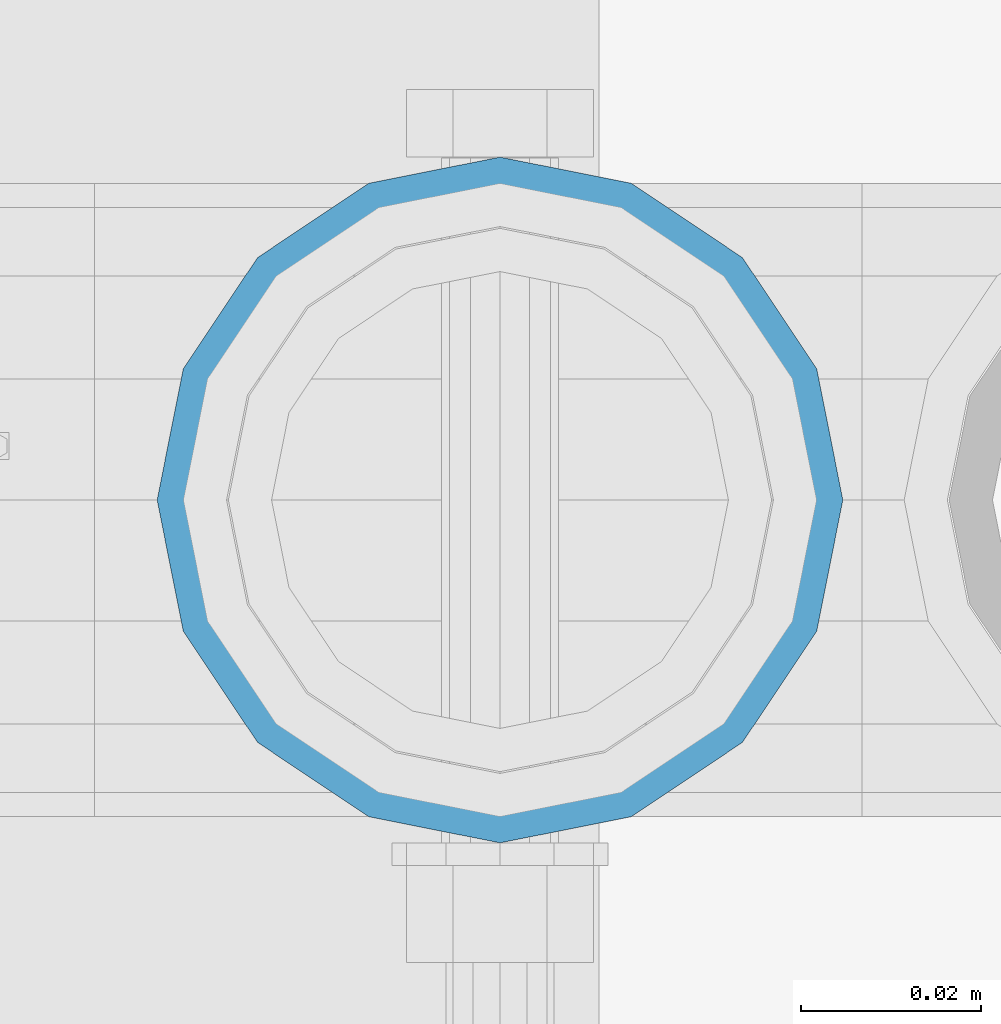
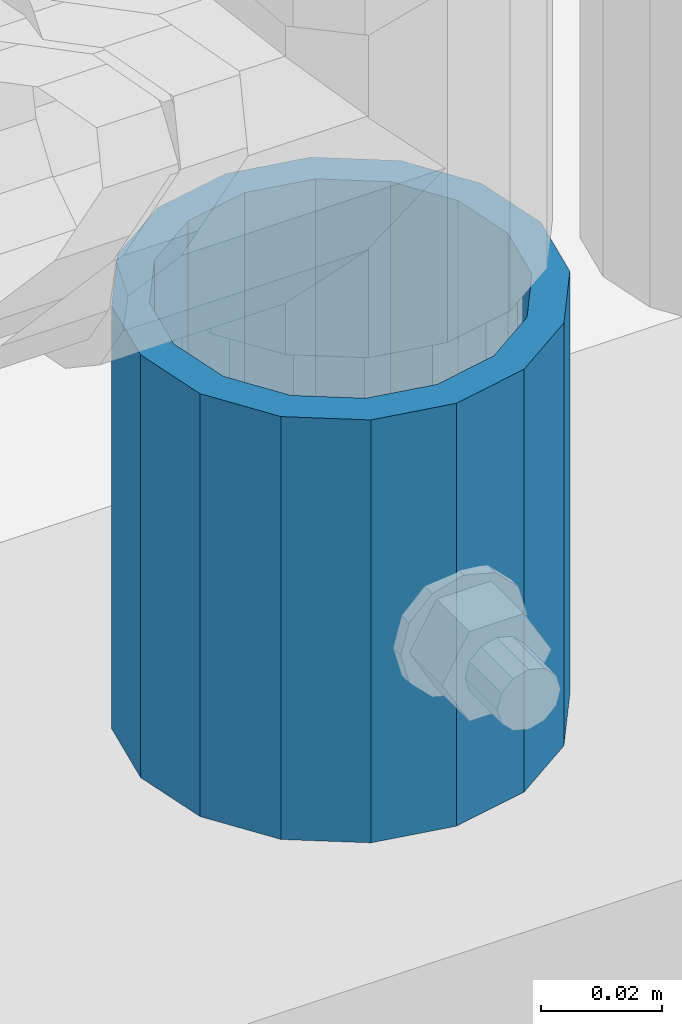
# One storey, part 113 of 270: 1 column.
"""IFC2X3 building model written with IfcOpenShell, lengths in millimetres."""

from ifc_helpers import new_model, si_unit, frame, origin_with_axes, place, context, subcontext, project, spatial, faceted_brep, material, type_object, element, save


model = new_model("IFC2X3")

# Units and contexts
model_context = context("Model", 3, precision=1e-05, world=origin_with_axes())
body_context = subcontext(model_context, "Body", "Model", "MODEL_VIEW")
ifc_project = project(units=[si_unit("LENGTHUNIT", "METRE", prefix="MILLI"), si_unit("AREAUNIT", "SQUARE_METRE"), si_unit("VOLUMEUNIT", "CUBIC_METRE"), si_unit("MASSUNIT", "GRAM", prefix="KILO"), si_unit("TIMEUNIT", "SECOND"), si_unit("PLANEANGLEUNIT", "RADIAN"), si_unit("SOLIDANGLEUNIT", "STERADIAN"), si_unit("THERMODYNAMICTEMPERATUREUNIT", "DEGREE_CELSIUS"), si_unit("LUMINOUSINTENSITYUNIT", "LUMEN")], contexts=[model_context])

# Site, building, storey
site_placement = place(None, origin_with_axes())
site = spatial("IfcSite", under=ifc_project, at=site_placement, CompositionType="ELEMENT")
building_placement = place(site_placement, origin_with_axes())
building = spatial("IfcBuilding", under=site, at=building_placement, Name="Standard", CompositionType="ELEMENT")
storey_placement = place(building_placement, origin_with_axes())
storey = spatial("IfcBuildingStorey", under=building, at=storey_placement, Name="Undefined", CompositionType="ELEMENT", Elevation=0.0)

# Column
ifc_material = material()
column_type = type_object("IfcColumnType", PredefinedType="NOTDEFINED")
column_placement = place(storey_placement, frame((19794.0, -16335.5, 168.02), z_axis=(0.0, 1.0, 0.0), x_axis=(0.0, 0.0, 1.0)))
element("IfcColumn", 1, at=column_placement, inside=storey, type_object=column_type, material=ifc_material, context=body_context, shape_type="Brep", body=[
    faceted_brep([(0.0, -31.75, 0.0), (0.0, -29.3331751572332, 12.1501989775916), (85.0, -29.3331751572332, 12.1501989775916), (85.0, -31.75, 0.0), (0.0, -22.4506403026717, 22.4506403026735), (85.0, -22.4506403026717, 22.4506403026735), (0.0, -12.1501989775934, 29.3331751572332), (85.0, -12.1501989775934, 29.3331751572332), (0.0, 0.0, 31.75), (85.0, 0.0, 31.75), (0.0, 12.1501989775934, 29.3331751572332), (85.0, 12.1501989775934, 29.3331751572332), (0.0, 22.4506403026717, 22.4506403026735), (85.0, 22.4506403026717, 22.4506403026735), (0.0, 29.3331751572332, 12.1501989775916), (85.0, 29.3331751572332, 12.1501989775916), (0.0, 31.75, 0.0), (85.0, 31.75, 0.0), (0.0, 29.3331751572332, -12.1501989775916), (85.0, 29.3331751572332, -12.1501989775916), (0.0, 22.4506403026717, -22.4506403026735), (85.0, 22.4506403026717, -22.4506403026735), (0.0, 12.1501989775934, -29.3331751572332), (85.0, 12.1501989775934, -29.3331751572332), (0.0, 0.0, -31.75), (85.0, 0.0, -31.75), (0.0, -12.1501989775934, -29.3331751572332), (85.0, -12.1501989775934, -29.3331751572332), (0.0, -22.4506403026717, -22.4506403026735), (85.0, -22.4506403026717, -22.4506403026735), (0.0, -29.3331751572332, -12.1501989775916), (85.0, -29.3331751572332, -12.1501989775916), (0.0, -38.0499999999993, 0.0), (0.0, -35.1536162120537, -14.561104601491), (85.0, -35.1536162120537, -14.561104601491), (85.0, -38.0499999999993, 0.0), (0.0, -26.9054130241493, -26.9054130241475), (85.0, -26.9054130241493, -26.9054130241475), (0.0, -14.5611046014928, -35.1536162120537), (85.0, -14.5611046014928, -35.1536162120537), (0.0, 0.0, -38.0499999999993), (85.0, 0.0, -38.0499999999993), (0.0, 14.5611046014928, -35.1536162120537), (85.0, 14.5611046014928, -35.1536162120537), (0.0, 26.9054130241493, -26.9054130241475), (85.0, 26.9054130241493, -26.9054130241475), (0.0, 35.1536162120537, -14.561104601491), (85.0, 35.1536162120537, -14.561104601491), (0.0, 38.0499999999993, 0.0), (85.0, 38.0499999999993, 0.0), (0.0, 35.1536162120537, 14.561104601491), (85.0, 35.1536162120537, 14.561104601491), (0.0, 26.9054130241493, 26.9054130241475), (85.0, 26.9054130241493, 26.9054130241475), (0.0, 14.5611046014928, 35.1536162120537), (85.0, 14.5611046014928, 35.1536162120537), (0.0, 0.0, 38.0499999999993), (85.0, 0.0, 38.0499999999993), (0.0, -14.5611046014928, 35.1536162120537), (85.0, -14.5611046014928, 35.1536162120537), (0.0, -26.9054130241493, 26.9054130241475), (85.0, -26.9054130241493, 26.9054130241475), (0.0, -35.1536162120537, 14.561104601491), (85.0, -35.1536162120537, 14.561104601491)], [[[0, 1, 2, 3]], [[1, 4, 5, 2]], [[4, 6, 7, 5]], [[6, 8, 9, 7]], [[8, 10, 11, 9]], [[10, 12, 13, 11]], [[12, 14, 15, 13]], [[14, 16, 17, 15]], [[16, 18, 19, 17]], [[18, 20, 21, 19]], [[20, 22, 23, 21]], [[22, 24, 25, 23]], [[24, 26, 27, 25]], [[26, 28, 29, 27]], [[28, 30, 31, 29]], [[30, 0, 3, 31]], [[32, 33, 34, 35]], [[33, 36, 37, 34]], [[36, 38, 39, 37]], [[38, 40, 41, 39]], [[40, 42, 43, 41]], [[42, 44, 45, 43]], [[44, 46, 47, 45]], [[46, 48, 49, 47]], [[48, 50, 51, 49]], [[50, 52, 53, 51]], [[52, 54, 55, 53]], [[54, 56, 57, 55]], [[56, 58, 59, 57]], [[58, 60, 61, 59]], [[60, 62, 63, 61]], [[62, 32, 35, 63]], [[37, 39, 41, 43, 45, 47, 49, 51, 53, 55, 57, 59, 61, 63, 35, 34], [5, 7, 9, 11, 13, 15, 17, 19, 21, 23, 25, 27, 29, 31, 3, 2]], [[62, 60, 58, 56, 54, 52, 50, 48, 46, 44, 42, 40, 38, 36, 33, 32], [30, 28, 26, 24, 22, 20, 18, 16, 14, 12, 10, 8, 6, 4, 1, 0]]]),
])

save(model, "model.ifc")
